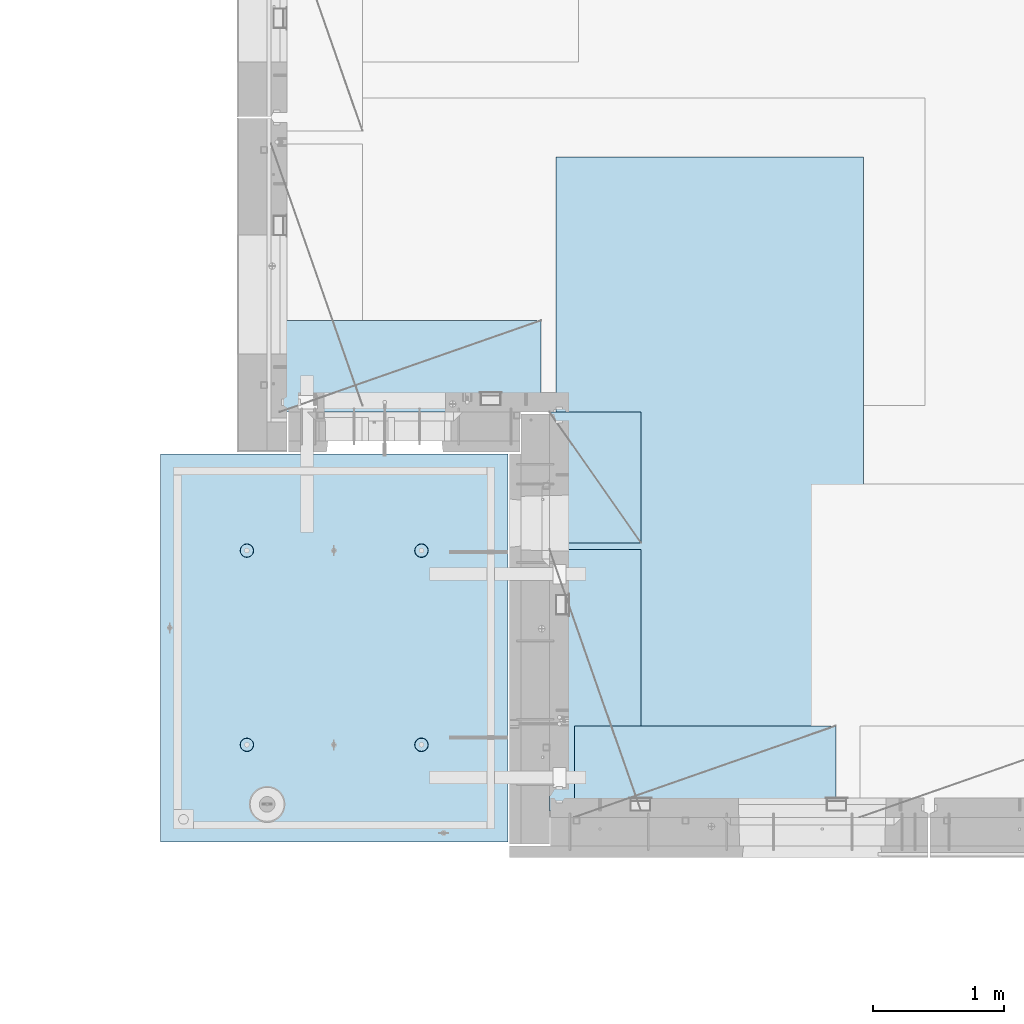
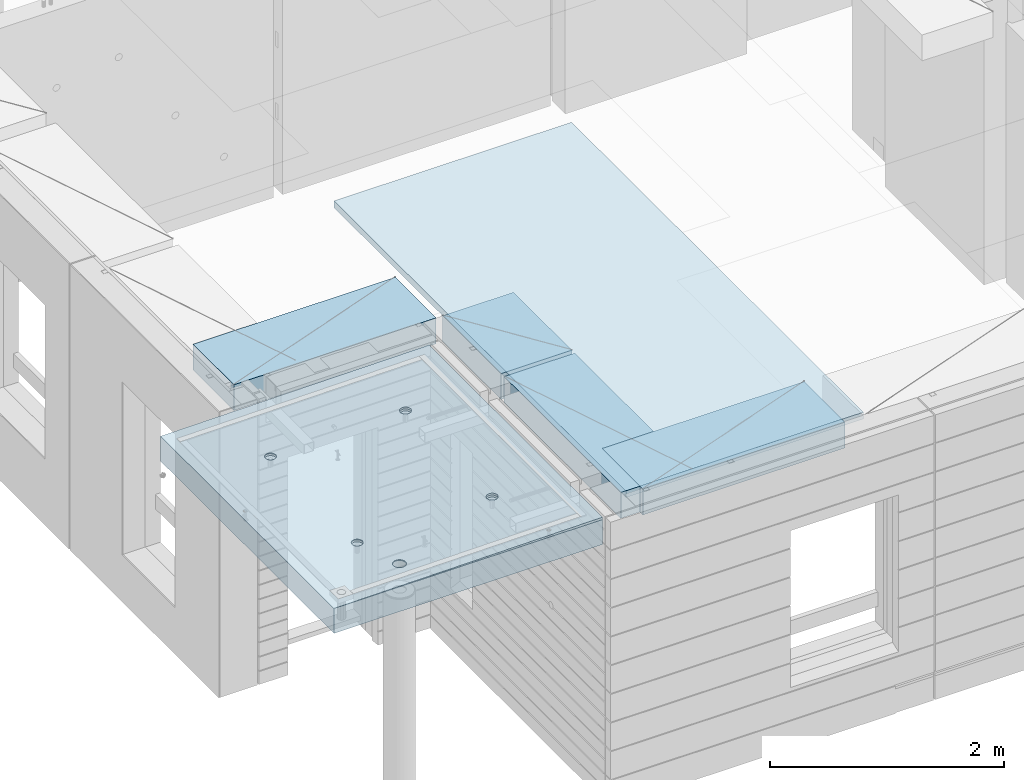
# One storey, part 200 of 350: 5 plates, 2 slabs, 6 elements without a shape of their own.
"""IFC2X3 building model written with IfcOpenShell, lengths in millimetres."""

from ifc_helpers import new_model, si_unit, frame, origin_with_axes, place, context, subcontext, project, spatial, faceted_brep, material, type_object, element, aggregate, save


model = new_model("IFC2X3")

# Units and contexts
model_context = context("Model", 3, precision=1e-05, world=origin_with_axes())
body_context = subcontext(model_context, "Body", "Model", "MODEL_VIEW")
ifc_project = project(units=[si_unit("LENGTHUNIT", "METRE", prefix="MILLI"), si_unit("AREAUNIT", "SQUARE_METRE"), si_unit("VOLUMEUNIT", "CUBIC_METRE"), si_unit("MASSUNIT", "GRAM", prefix="KILO"), si_unit("TIMEUNIT", "SECOND"), si_unit("PLANEANGLEUNIT", "RADIAN"), si_unit("SOLIDANGLEUNIT", "STERADIAN"), si_unit("THERMODYNAMICTEMPERATUREUNIT", "DEGREE_CELSIUS"), si_unit("LUMINOUSINTENSITYUNIT", "LUMEN")], contexts=[model_context])

# Site, building, storey
site_placement = place(None, origin_with_axes())
site = spatial("IfcSite", under=ifc_project, at=site_placement, CompositionType="ELEMENT")
building_placement = place(site_placement, origin_with_axes())
building = spatial("IfcBuilding", under=site, at=building_placement, CompositionType="ELEMENT")
storey_placement = place(building_placement, origin_with_axes())
storey = spatial("IfcBuildingStorey", under=building, at=storey_placement, Name="2", CompositionType="ELEMENT", Elevation=0.0)

# Assembly, slabs
assembly_1_placement = place(storey_placement, origin_with_axes())
assembly_1 = element("IfcElementAssembly", 1, at=assembly_1_placement, inside=storey, AssemblyPlace="NOTDEFINED", PredefinedType="REINFORCEMENT_UNIT")
ifc_material_1 = material(Name="CONCRETE/C35/45")
slab_type_1 = type_object("IfcSlabType", PredefinedType="NOTDEFINED")
slab_1_placement = place(assembly_1_placement, frame((9690.00344264774, 7659.99985681325, 87717.5), z_axis=(-1.0, 3.00000001838171e-08, 0.0), x_axis=(0.0, 1.0, 0.0)))
slab_1 = element("IfcSlab", 2, at=slab_1_placement, type_object=slab_type_1, material=ifc_material_1, PredefinedType="FLOOR", context=body_context, shape_type="Brep", body=[
    faceted_brep([(2970.0, 12.5, 2076.56396484375), (2970.0, 12.5, 2655.10375976563), (2970.0, 7.05330645262438, 2076.56396484375), (2970.0, 12.5, 0.0), (2969.99999999997, -12.5000027287315, -0.000215120240682154), (7.41420080885291e-08, 12.4999999999927, 0.0), (-7.41420080885291e-08, -12.5, -3.63797880709171e-12), (0.0, 12.5, 2655.00366210938), (2246.17288192116, -6.7539579669974, 610.235903379627), (2245.81872714612, 12.5, 611.325879700402), (2230.00000005311, 12.5, 608.820439463128), (2230.00000005311, -6.77809034052189, 607.672934085716), (2260.76019932669, -6.68392947182292, 617.673133503364), (2260.0890070157, 12.5, 618.596950465364), (2272.332530811, -6.57487936261168, 629.254531739907), (2271.41396524135, 12.5, 629.921908691014), (2279.75709784774, -6.43750647555862, 643.843854552742), (2278.68503600632, 12.5, 644.192188560603), (2282.30864751904, -6.2852774275234, 660.010915653605), (2281.19047624359, 12.5, 660.010915653605), (2279.73986529519, -6.13310092446045, 676.172377558725), (2278.68503600632, 12.5, 675.829642746608), (2272.30464795307, -5.995865551522, 690.747041485218), (2271.41396524135, 12.5, 690.099922616197), (2260.73231646608, -5.88698525390646, 702.310320338618), (2260.0890070157, 12.5, 701.424880841847), (2246.15564936427, -5.81709377811057, 709.732891570933), (2245.81872714612, 12.5, 708.695951606809), (2230.00000005311, -5.7930130083696, 712.290261666009), (2230.00000005311, 12.5, 711.201391844083), (2213.8443507625, -5.8170926610037, 709.732891507694), (2214.18127296011, 12.5, 708.695951606811), (2199.2676837145, -5.88698312871566, 702.310320236276), (2199.91099309052, 12.5, 701.424880841847), (2187.69535229405, -5.99586262571393, 690.747041382852), (2188.58603486487, 12.5, 690.099922616197), (2180.26013500581, -6.13309748387837, 676.172377495441), (2181.31496409991, 12.5, 675.829642746608), (2177.6913528026, -6.28527380865125, 660.010915653605), (2178.80952386264, 12.5, 660.010915653605), (2180.24290245339, -6.43750303260458, 643.843854616072), (2181.31496409991, 12.5, 644.192188560603), (2187.66746943631, -6.57487643294735, 629.254531842409), (2188.58603486487, 12.5, 629.921908691014), (2199.23980085403, -6.68392734277586, 617.673133605889), (2199.91099309052, 12.5, 618.596950465364), (2213.82711820565, -6.75395684751857, 610.235903443003), (2214.18127296011, 12.5, 611.325879700402), (761.172882674973, -6.75400078258826, 610.225900828256), (760.818727112381, 12.5, 611.315879572843), (745.000000019378, 12.5, 608.81043933557), (745.000000019378, -6.77813315729145, 607.662931409541), (775.760200790834, -6.68397228400863, 617.663131314152), (775.089006981969, 12.5, 618.586950337805), (787.33253283866, -6.57492216948594, 629.244530114656), (786.413965207619, 12.5, 629.911908563456), (794.757100236948, -6.437549275739, 643.833853637923), (793.685035972581, 12.5, 644.182188433044), (797.308650032492, -6.28532022031141, 660.000915526047), (796.190476209855, 12.5, 660.000915526047), (794.739867683551, -6.13314370981243, 676.162378218156), (793.685035972581, 12.5, 675.81964261905), (787.304649979378, -5.9959083302092, 690.737042854367), (786.413965207619, 12.5, 690.089922488638), (775.732317928869, -5.88702802728221, 702.300322270843), (775.089006981969, 12.5, 701.414880714288), (761.155650117242, -5.81713654809573, 709.722893864604), (760.818727112381, 12.5, 708.68595147925), (745.000000019378, -5.79305577717605, 712.280264084213), (745.000000019378, 12.5, 711.191391716524), (728.844349942063, -5.8171354309743, 709.722893801363), (729.181272926375, 12.5, 708.68595147925), (714.267682184241, -5.88702590207686, 702.300322168503), (714.910993056787, 12.5, 701.414880714288), (702.695350200273, -5.99590540440113, 690.737042752), (703.586034831136, 12.5, 690.089922488638), (695.260132549976, -6.1331402692449, 676.16237815487), (696.314964066174, 12.5, 675.81964261905), (692.691350221674, -6.28531660142471, 660.000915526047), (693.809523828902, 12.5, 660.000915526047), (695.242899996714, -6.43754583279951, 643.833853701251), (696.314964066174, 12.5, 644.182188433044), (702.667467341174, -6.57491923982161, 629.244530217156), (703.586034831136, 12.5, 629.911908563456), (714.239799322411, -6.68397015496157, 617.663131416677), (714.910993056787, 12.5, 618.586950337805), (728.827117384375, -6.75399966310943, 610.225900891632), (729.181272926375, 12.5, 611.315879572843), (760.941541335169, 5.82308796475991, 1945.93972725137), (760.818727091786, 12.5, 1946.31771062636), (744.999999998783, 12.5, 1943.81227038909), (744.999999998783, 5.79930078610778, 1943.4134192454), (775.320198478928, 5.89211475661432, 1953.2705735664), (775.089006961374, 12.5, 1953.58878139132), (786.72699673669, 5.99960498859582, 1964.68630888353), (786.413965187025, 12.5, 1964.91373961697), (794.045361100365, 6.13501286304381, 1979.06694274881), (793.685035951987, 12.5, 1979.18401948656), (796.560412832556, 6.28506439260673, 1995.00274657956), (796.190476189258, 12.5, 1995.00274657956), (794.028375046106, 6.43506412883289, 2010.93303130673), (793.685035951987, 12.5, 2010.82147367257), (786.699512721421, 6.57033645619231, 2025.29921596966), (786.413965187025, 12.5, 2025.09175354215), (775.292714461017, 6.67765930559835, 2036.69709108738), (775.089006961374, 12.5, 2036.41671176781), (760.924555276639, 6.74655103802797, 2044.01348819506), (760.818727091786, 12.5, 2043.68778253277), (744.999999998783, 6.7702873510425, 2046.53427709438), (744.999999998783, 12.5, 2046.19322277004), (729.075444741182, 6.7465521391714, 2044.01348813272), (729.18127290578, 12.5, 2043.68778253277), (714.70728560984, 6.67766140039021, 2036.6970909865), (714.910993036192, 12.5, 2036.41671176781), (703.300487415023, 6.57033934014908, 2025.29921586876), (703.586034810542, 12.5, 2025.09175354216), (695.971625143447, 6.43506752018584, 2010.93303124435), (696.314964045579, 12.5, 2010.82147367257), (693.439587377337, 6.28506795971771, 1995.00274657956), (693.809523808306, 12.5, 1995.00274657956), (695.954639089321, 6.13501625673962, 1979.06694281123), (696.314964045579, 12.5, 1979.18401948656), (703.273003399938, 5.99960787635064, 1964.68630898457), (703.586034810542, 12.5, 1964.91373961697), (714.679801592063, 5.89211685521877, 1953.27057366746), (714.910993036192, 12.5, 1953.58878139132), (729.058458682694, 5.82308906823164, 1945.93972731384), (729.18127290578, 12.5, 1946.31771062636), (2178.80952377932, 12.5, 1995.00274667064), (2178.43958429075, 6.28501659208268, 1995.00274667064), (2180.95463615188, 6.13496488021337, 1979.06694195729), (2181.31496401659, 12.5, 1979.18401957764), (2181.31496401659, 12.5, 2010.82147376364), (2180.97162220701, 6.43501616145659, 2010.93303228012), (2188.58603478155, 12.5, 2025.09175363323), (2188.3004849132, 6.57028798943793, 2025.29921775646), (2199.9109930072, 12.5, 2036.41671185888), (2199.70728378446, 6.6776100560528, 2036.6970935501), (2214.18127287679, 12.5, 2043.68778262385), (2214.07544376785, 6.74650079890853, 2044.0134911302), (2229.9999999698, 12.5, 2046.19322286112), (2229.9999999698, 6.77023601217661, 2046.53428024135), (2245.8187270628, 12.5, 2043.68778262385), (2245.924556192, 6.7464996977651, 2044.01349119253), (2260.08900693239, 12.5, 2036.41671185888), (2260.29271622843, 6.67760796126095, 2036.69709365098), (2271.41396515804, 12.5, 2025.09175363323), (2271.69951516527, 6.57028510548116, 2025.29921785736), (2278.685035923, 12.5, 2010.82147376364), (2279.02837792456, 6.43501277010364, 2010.9330323425), (2281.19047616027, 12.5, 1995.00274667064), (2281.56041586117, 6.2850130249717, 1995.00274667064), (2278.685035923, 12.5, 1979.18401957764), (2279.04536397983, 6.13496148651757, 1979.06694189487), (2271.41396515804, 12.5, 1964.91373970805), (2271.72699918216, 5.99955360403692, 1964.68630717681), (2260.08900693239, 12.5, 1953.5887814824), (2260.32020024797, 5.89206336568168, 1953.2705711827), (2245.8187270628, 12.5, 1946.31771071744), (2245.94154225154, 5.82303656973818, 1945.93972443295), (254.731823253564, 4.36849820162752, 1791.45731182264), (241.457918728614, 4.49348581883532, 1804.73121634759), (232.935547413403, 4.65097912067722, 1821.45731182264), (229.998938391112, 4.82556156541978, 1839.99833148514), (232.935547413403, 5.00014380698849, 1858.53935114764), (241.457918728614, 5.15763651921588, 1875.26544662269), (254.731823253564, 5.28262321809598, 1888.53935114764), (271.457918728614, 5.36286933471274, 1897.06172246285), (289.998938391112, 5.3905198200664, 1899.99833148514), (308.539958053609, 5.36286805199052, 1897.06172246285), (325.26605352866, 5.28262077822001, 1888.53935114764), (338.539958053609, 5.15763316099765, 1875.26544662269), (347.06232936882, 5.0001398591703, 1858.53935114764), (349.998938391112, 4.82555741442775, 1839.99833148514), (347.06232936882, 4.65097517284448, 1821.45731182264), (338.539958053609, 4.49348246061709, 1804.73121634759), (325.26605352866, 4.36849576173699, 1791.45731182264), (308.539958053609, 4.28824964510568, 1782.93494050743), (289.998938391112, 4.26059915976657, 1779.99833148514), (271.457918728614, 4.28825092784246, 1782.93494050743), (2199.67979976505, 5.89206546428613, 1953.27057128376), (2188.27300089649, 5.99955649179174, 1964.68630727784), (2229.9999999698, 5.79924938967451, 1943.41341627717), (2214.05845770835, 5.82303767320991, 1945.93972449542), (2188.58603478155, 12.5, 1964.91373970805), (2199.9109930072, 12.5, 1953.5887814824), (2214.18127287679, 12.5, 1946.31771071744), (2229.9999999698, 12.5, 1943.81227048017), (325.26605352866, 12.5, 1791.45731182264), (338.539958053609, 12.5, 1804.73121634759), (347.06232936882, 12.5, 1821.45731182264), (349.998938391112, 12.5, 1839.99833148514), (347.06232936882, 12.5, 1858.53935114764), (338.539958053609, 12.5, 1875.26544662269), (325.26605352866, 12.5, 1888.53935114764), (308.539958053609, 12.5, 1897.06172246285), (289.998938391112, 12.5, 1899.99833148514), (271.457918728614, 12.5, 1897.06172246285), (254.731823253564, 12.5, 1888.53935114764), (241.457918728614, 12.5, 1875.26544662269), (232.935547413403, 12.5, 1858.53935114764), (229.998938391112, 12.5, 1839.99833148514), (232.935547413403, 12.5, 1821.45731182264), (241.457918728614, 12.5, 1804.73121634759), (254.731823253564, 12.5, 1791.45731182264), (271.457918728614, 12.5, 1782.93494050743), (289.998938391112, 12.5, 1779.99833148514), (308.539958053609, 12.5, 1782.93494050743)], [[[0, 1, 2]], [[3, 0, 2, 4]], [[5, 3, 4, 6]], [[5, 6, 7]], [[8, 9, 10, 11]], [[12, 13, 9, 8]], [[14, 15, 13, 12]], [[16, 17, 15, 14]], [[18, 19, 17, 16]], [[20, 21, 19, 18]], [[21, 20, 22, 23]], [[23, 22, 24, 25]], [[25, 24, 26, 27]], [[27, 26, 28, 29]], [[29, 28, 30, 31]], [[31, 30, 32, 33]], [[33, 32, 34, 35]], [[35, 34, 36, 37]], [[37, 36, 38, 39]], [[40, 41, 39, 38]], [[42, 43, 41, 40]], [[44, 45, 43, 42]], [[46, 47, 45, 44]], [[11, 10, 47, 46]], [[48, 49, 50, 51]], [[52, 53, 49, 48]], [[54, 55, 53, 52]], [[56, 57, 55, 54]], [[58, 59, 57, 56]], [[60, 61, 59, 58]], [[61, 60, 62, 63]], [[63, 62, 64, 65]], [[65, 64, 66, 67]], [[67, 66, 68, 69]], [[69, 68, 70, 71]], [[71, 70, 72, 73]], [[73, 72, 74, 75]], [[75, 74, 76, 77]], [[77, 76, 78, 79]], [[80, 81, 79, 78]], [[82, 83, 81, 80]], [[84, 85, 83, 82]], [[86, 87, 85, 84]], [[51, 50, 87, 86]], [[88, 89, 90, 91]], [[92, 93, 89, 88]], [[94, 95, 93, 92]], [[96, 97, 95, 94]], [[98, 99, 97, 96]], [[100, 101, 99, 98]], [[102, 103, 101, 100]], [[104, 105, 103, 102]], [[105, 104, 106, 107]], [[107, 106, 108, 109]], [[109, 108, 110, 111]], [[111, 110, 112, 113]], [[113, 112, 114, 115]], [[115, 114, 116, 117]], [[117, 116, 118, 119]], [[119, 118, 120, 121]], [[121, 120, 122, 123]], [[124, 125, 123, 122]], [[126, 127, 125, 124]], [[91, 90, 127, 126]], [[128, 129, 130, 131]], [[132, 133, 129, 128]], [[134, 135, 133, 132]], [[136, 137, 135, 134]], [[138, 139, 137, 136]], [[140, 141, 139, 138]], [[142, 143, 141, 140]], [[144, 145, 143, 142]], [[145, 144, 146, 147]], [[147, 146, 148, 149]], [[149, 148, 150, 151]], [[151, 150, 152, 153]], [[153, 152, 154, 155]], [[155, 154, 156, 157]], [[157, 156, 158, 159]], [[4, 2, 1, 7, 6], [160, 161, 162, 163, 164, 165, 166, 167, 168, 169, 170, 171, 172, 173, 174, 175, 176, 177, 178, 179], [180, 181, 130, 129, 133, 135, 137, 139, 141, 143, 145, 147, 149, 151, 153, 155, 157, 159, 182, 183], [124, 122, 120, 118, 116, 114, 112, 110, 108, 106, 104, 102, 100, 98, 96, 94, 92, 88, 91, 126], [84, 82, 80, 78, 76, 74, 72, 70, 68, 66, 64, 62, 60, 58, 56, 54, 52, 48, 51, 86], [44, 42, 40, 38, 36, 34, 32, 30, 28, 26, 24, 22, 20, 18, 16, 14, 12, 8, 11, 46]], [[131, 130, 181, 184]], [[180, 185, 184, 181]], [[183, 186, 185, 180]], [[182, 187, 186, 183]], [[159, 158, 187, 182]], [[0, 3, 5, 7, 1], [188, 189, 190, 191, 192, 193, 194, 195, 196, 197, 198, 199, 200, 201, 202, 203, 204, 205, 206, 207], [156, 154, 152, 150, 148, 146, 144, 142, 140, 138, 136, 134, 132, 128, 131, 184, 185, 186, 187, 158], [93, 95, 97, 99, 101, 103, 105, 107, 109, 111, 113, 115, 117, 119, 121, 123, 125, 127, 90, 89], [53, 55, 57, 59, 61, 63, 65, 67, 69, 71, 73, 75, 77, 79, 81, 83, 85, 87, 50, 49], [13, 15, 17, 19, 21, 23, 25, 27, 29, 31, 33, 35, 37, 39, 41, 43, 45, 47, 10, 9]], [[178, 206, 205, 179]], [[177, 207, 206, 178]], [[176, 188, 207, 177]], [[175, 189, 188, 176]], [[174, 190, 189, 175]], [[173, 191, 190, 174]], [[172, 192, 191, 173]], [[171, 193, 192, 172]], [[170, 194, 193, 171]], [[169, 195, 194, 170]], [[168, 196, 195, 169]], [[167, 197, 196, 168]], [[166, 198, 197, 167]], [[165, 199, 198, 166]], [[164, 200, 199, 165]], [[163, 201, 200, 164]], [[162, 202, 201, 163]], [[161, 203, 202, 162]], [[160, 204, 203, 161]], [[179, 205, 204, 160]]]),
])
slab_type_2 = type_object("IfcSlabType", PredefinedType="NOTDEFINED")
slab_2_placement = place(assembly_1_placement, frame((9690.00344264774, 7659.99985681325, 87575.0), z_axis=(-0.999999999997437, -2.26400000064461e-06, 0.0), x_axis=(-2.2639999995273e-06, 0.999999999997437, 0.0)))
slab_2 = element("IfcSlab", 3, at=slab_2_placement, type_object=slab_type_2, material=ifc_material_1, PredefinedType="FLOOR", context=body_context, shape_type="Brep", body=[
    faceted_brep([(2245.45536387143, -110.0, 1947.44471589559), (2259.39379322965, -110.0, 1954.54665968234), (2270.4554059745, -110.0, 1965.60822114567), (2277.55741437973, -110.0, 1979.54661757913), (2280.00462438004, -110.0, 1994.99746162528), (2277.55748600988, -110.0, 2010.44831701654), (2270.45554222312, -110.0, 2024.38674637476), (2259.39398075979, -110.0, 2035.44835911961), (2245.45558432633, -110.0, 2042.55036752485), (2230.00474028018, -110.0, 2044.99757752515), (2214.55388488892, -110.0, 2042.55043915498), (2200.6154555307, -110.0, 2035.44849536823), (2189.55384278585, -110.0, 2024.3869339049), (2182.45183438062, -110.0, 2010.44853747144), (2180.00462438031, -110.0, 1994.99769342529), (2182.45176275048, -110.0, 1979.54683803403), (2189.55370653723, -110.0, 1965.60840867581), (2200.61526800056, -110.0, 1954.54679593096), (2214.55366443402, -110.0, 1947.44478752572), (2230.00450848018, -110.0, 1944.99757752542), (2260.09353534512, -130.0, 1953.58354259084), (2245.82323862122, -130.0, 1946.3125049044), (2271.41851982199, -130.0, 1964.9084745652), (2278.68962366544, -130.0, 1979.17873758041), (2281.19510057052, -130.0, 1994.99745886576), (2278.68969700106, -130.0, 2010.81619176633), (2271.41865931462, -130.0, 2025.08648849022), (2260.09372734026, -130.0, 2036.4114729671), (2245.82346432505, -130.0, 2043.68257681055), (2230.0047430397, -130.0, 2046.18805371562), (2214.18601013913, -130.0, 2043.68265014617), (2199.91571341524, -130.0, 2036.41161245973), (2188.59072893836, -130.0, 2025.08668048537), (2181.31962509491, -130.0, 2010.81641747016), (2178.81414818984, -130.0, 1994.99769618481), (2181.31955175929, -130.0, 1979.17896328424), (2188.59058944573, -130.0, 1964.90866656035), (2199.91552142009, -130.0, 1953.58368208347), (2214.1857844353, -130.0, 1946.31257824002), (2230.00450572065, -130.0, 1943.80710133495), (760.455363904408, -110.0, 1947.44815803451), (774.393793262629, -110.0, 1954.55010182126), (785.455406007481, -110.0, 1965.61166328459), (792.557414412711, -110.0, 1979.55005971805), (795.004624413019, -110.0, 1995.00090376421), (792.557486042851, -110.0, 2010.45175915546), (785.455542256102, -110.0, 2024.39018851368), (774.393980792767, -110.0, 2035.45180125853), (760.455584359308, -110.0, 2042.55380966377), (745.004740313152, -110.0, 2045.00101966407), (729.553884921896, -110.0, 2042.55388129391), (715.615455563677, -110.0, 2035.45193750716), (704.553842818825, -110.0, 2024.39037604382), (697.451834413594, -110.0, 2010.45197961036), (695.004624413286, -110.0, 1995.00113556421), (697.451762783454, -110.0, 1979.55028017295), (704.553706570203, -110.0, 1965.61185081473), (715.615268033538, -110.0, 1954.55023806988), (729.553664466996, -110.0, 1947.44822966465), (745.004508513151, -110.0, 1945.00101966434), (760.823238654199, -130.0, 1946.31594704332), (745.004505753628, -130.0, 1943.81054347387), (775.093535378091, -130.0, 1953.58698472976), (786.418519854964, -130.0, 1964.91191670413), (793.689623698416, -130.0, 1979.18217971933), (796.195100603492, -130.0, 1995.00090100468), (793.689697034035, -130.0, 2010.81963390525), (786.418659347601, -130.0, 2025.08993062915), (775.093727373234, -130.0, 2036.41491510602), (760.823464358025, -130.0, 2043.68601894947), (745.004743072675, -130.0, 2046.19149585455), (729.186010172105, -130.0, 2043.68609228509), (714.915713448214, -130.0, 2036.41505459866), (703.590728971341, -130.0, 2025.09012262429), (696.319625127888, -130.0, 2010.81985960908), (693.814148222813, -130.0, 1995.00113832373), (696.319551792269, -130.0, 1979.18240542316), (703.590589478705, -130.0, 1964.91210869927), (714.915521453071, -130.0, 1953.5871242224), (729.185784468278, -130.0, 1946.31602037894), (2970.0, -130.0, 1.11504050437361e-09), (0.0, -130.0, -3.63797880709171e-12), (0.0, 130.0, -1.81898940354586e-12), (2970.0, 130.0, 1.11504050437361e-09), (2970.0048828125, -130.0, 2076.55712890625), (2970.0048828125, 130.0, 2076.55712890625), (2970.00610351563, -130.0, 2655.0966796875), (2970.00610351563, 130.0, 2655.0966796875), (0.00277573079893045, -130.0, 2655.00366210937), (0.00277573079893045, 130.0, 2655.00366210937), (325.270206125839, 130.0, 1791.45655785112), (338.544141419662, 130.0, 1804.73043160713), (347.066551505941, 130.0, 1821.45650732727), (350.003203506308, 130.0, 1839.99752018266), (347.066637462108, 130.0, 1858.53854665217), (338.544304918008, 130.0, 1875.26466188203), (325.270431162006, 130.0, 1888.53859717586), (308.544355441856, 130.0, 1897.06100726213), (290.003342586469, 130.0, 1899.9976592625), (271.462316116962, 130.0, 1897.0610932183), (254.7362008871, 130.0, 1888.5387606742), (241.462265593274, 130.0, 1875.2648869182), (232.939855506997, 130.0, 1858.53881119805), (230.00320350663, 130.0, 1839.99779834266), (232.93976955083, 130.0, 1821.45677187316), (241.462102094929, 130.0, 1804.73065664329), (254.735975850932, 130.0, 1791.45672134947), (271.462051571081, 130.0, 1782.93431126319), (290.003064426469, 130.0, 1779.99765926282), (308.544090895975, 130.0, 1782.93422530702), (308.544090895975, -130.0, 1782.93422530702), (290.003064426469, -130.0, 1779.99765926282), (325.270206125839, -130.0, 1791.45655785112), (338.544141419662, -130.0, 1804.73043160713), (347.066551505941, -130.0, 1821.45650732727), (350.003203506308, -130.0, 1839.99752018266), (347.066637462108, -130.0, 1858.53854665217), (338.544304918008, -130.0, 1875.26466188203), (325.270431162006, -130.0, 1888.53859717586), (308.544355441856, -130.0, 1897.06100726213), (290.003342586469, -130.0, 1899.9976592625), (271.462316116962, -130.0, 1897.0610932183), (254.7362008871, -130.0, 1888.5387606742), (241.462265593274, -130.0, 1875.2648869182), (232.939855506997, -130.0, 1858.53881119805), (230.00320350663, -130.0, 1839.99779834266), (232.93976955083, -130.0, 1821.45677187316), (241.462102094929, -130.0, 1804.73065664329), (254.735975850932, -130.0, 1791.45672134947), (271.462051571081, -130.0, 1782.93431126319), (760.452269390758, -110.0, 612.446326984578), (774.390698748979, -110.0, 619.548270771327), (785.452311493831, -110.0, 630.609832234661), (792.554319899062, -110.0, 644.54822866812), (795.001529899369, -110.0, 659.999072714278), (792.554391529202, -110.0, 675.449928105532), (785.452447742453, -110.0, 689.388357463751), (774.390886279118, -110.0, 700.449970208605), (760.452489845658, -110.0, 707.551978613836), (745.001645799503, -110.0, 709.999188614142), (729.550790408246, -110.0, 707.552050243974), (715.612361050027, -110.0, 700.450106457225), (704.550748305175, -110.0, 689.388544993892), (697.448739899944, -110.0, 675.450148560432), (695.001529899637, -110.0, 659.999304514276), (697.448668269804, -110.0, 644.54844912302), (704.550612056553, -110.0, 630.610019764801), (715.612173519889, -110.0, 619.548407019947), (729.550569953346, -110.0, 612.446398614717), (745.001413999502, -110.0, 609.999188614411), (760.820144140549, -130.0, 611.314115993395), (745.001411239979, -130.0, 608.808712423936), (775.090440864442, -130.0, 618.585153679829), (786.415425341314, -130.0, 629.910085654195), (793.686529184766, -130.0, 644.180348669403), (796.192006089843, -130.0, 659.999069954752), (793.686602520385, -130.0, 675.817802855323), (786.415564833951, -130.0, 690.088099579216), (775.090632859585, -130.0, 701.41308405609), (760.820369844376, -130.0, 708.68418789954), (745.001648559026, -130.0, 711.189664804615), (729.182915658455, -130.0, 708.684261235159), (714.912618934564, -130.0, 701.413223548725), (703.587634457692, -130.0, 690.088291574357), (696.316530614238, -130.0, 675.81802855915), (693.811053709163, -130.0, 659.999307273802), (696.316457278619, -130.0, 644.180574373229), (703.587494965055, -130.0, 629.910277649336), (714.912426939421, -130.0, 618.585293172464), (729.182689954629, -130.0, 611.314189329014), (2245.45226944368, -110.0, 612.452884882137), (2259.3906988019, -110.0, 619.554828668886), (2270.45231154675, -110.0, 630.61639013222), (2277.55431995199, -110.0, 644.554786565679), (2280.00152995229, -110.0, 660.005630611837), (2277.55439158212, -110.0, 675.456486003091), (2270.45244779537, -110.0, 689.39491536131), (2259.39088633204, -110.0, 700.456528106164), (2245.45248989858, -110.0, 707.558536511395), (2230.00164585242, -110.0, 710.005746511701), (2214.55079046117, -110.0, 707.558608141533), (2200.61236110295, -110.0, 700.456664354784), (2189.5507483581, -110.0, 689.395102891451), (2182.44873995286, -110.0, 675.456706457991), (2180.00152995256, -110.0, 660.005862411836), (2182.44866832273, -110.0, 644.555007020579), (2189.55061210948, -110.0, 630.61657766236), (2200.61217357281, -110.0, 619.554964917506), (2214.55057000627, -110.0, 612.452956512276), (2230.00141405243, -110.0, 610.00574651197), (2245.82014419347, -130.0, 611.320673890954), (2230.0014112929, -130.0, 608.815270321495), (2260.09044091736, -130.0, 618.591711577388), (2271.41542539424, -130.0, 629.916643551753), (2278.68652923769, -130.0, 644.186906566962), (2281.19200614276, -130.0, 660.005627852312), (2278.68660257331, -130.0, 675.824360752882), (2271.41556488687, -130.0, 690.094657476773), (2260.09063291251, -130.0, 701.419641953647), (2245.8203698973, -130.0, 708.690745797099), (2230.00164861195, -130.0, 711.196222702174), (2214.18291571138, -130.0, 708.690819132718), (2199.91261898749, -130.0, 701.419781446282), (2188.58763451061, -130.0, 690.094849471916), (2181.31653066716, -130.0, 675.824586456709), (2178.81105376209, -130.0, 660.005865171361), (2181.31645733154, -130.0, 644.187132270788), (2188.58749501798, -130.0, 629.916835546896), (2199.91242699234, -130.0, 618.591851070023), (2214.18269000755, -130.0, 611.320747226573)], [[[0, 1, 2, 3, 4, 5, 6, 7, 8, 9, 10, 11, 12, 13, 14, 15, 16, 17, 18, 19]], [[20, 1, 0, 21]], [[22, 2, 1, 20]], [[23, 3, 2, 22]], [[24, 4, 3, 23]], [[25, 5, 4, 24]], [[26, 6, 5, 25]], [[27, 7, 6, 26]], [[28, 8, 7, 27]], [[29, 9, 8, 28]], [[30, 10, 9, 29]], [[31, 11, 10, 30]], [[32, 12, 11, 31]], [[33, 13, 12, 32]], [[34, 14, 13, 33]], [[35, 15, 14, 34]], [[36, 16, 15, 35]], [[37, 17, 16, 36]], [[38, 18, 17, 37]], [[39, 19, 18, 38]], [[21, 0, 19, 39]], [[40, 41, 42, 43, 44, 45, 46, 47, 48, 49, 50, 51, 52, 53, 54, 55, 56, 57, 58, 59]], [[60, 40, 59, 61]], [[62, 41, 40, 60]], [[63, 42, 41, 62]], [[64, 43, 42, 63]], [[65, 44, 43, 64]], [[66, 45, 44, 65]], [[67, 46, 45, 66]], [[68, 47, 46, 67]], [[69, 48, 47, 68]], [[70, 49, 48, 69]], [[71, 50, 49, 70]], [[72, 51, 50, 71]], [[73, 52, 51, 72]], [[74, 53, 52, 73]], [[75, 54, 53, 74]], [[76, 55, 54, 75]], [[77, 56, 55, 76]], [[78, 57, 56, 77]], [[79, 58, 57, 78]], [[61, 59, 58, 79]], [[80, 81, 82, 83]], [[84, 80, 83, 85]], [[86, 84, 85, 87]], [[88, 86, 87, 89]], [[81, 88, 89, 82]], [[87, 85, 83, 82, 89], [90, 91, 92, 93, 94, 95, 96, 97, 98, 99, 100, 101, 102, 103, 104, 105, 106, 107, 108, 109]], [[110, 109, 108, 111]], [[112, 90, 109, 110]], [[113, 91, 90, 112]], [[114, 92, 91, 113]], [[115, 93, 92, 114]], [[116, 94, 93, 115]], [[117, 95, 94, 116]], [[118, 96, 95, 117]], [[119, 97, 96, 118]], [[120, 98, 97, 119]], [[121, 99, 98, 120]], [[122, 100, 99, 121]], [[123, 101, 100, 122]], [[124, 102, 101, 123]], [[125, 103, 102, 124]], [[126, 104, 103, 125]], [[127, 105, 104, 126]], [[128, 106, 105, 127]], [[129, 107, 106, 128]], [[111, 108, 107, 129]], [[130, 131, 132, 133, 134, 135, 136, 137, 138, 139, 140, 141, 142, 143, 144, 145, 146, 147, 148, 149]], [[150, 130, 149, 151]], [[152, 131, 130, 150]], [[153, 132, 131, 152]], [[154, 133, 132, 153]], [[155, 134, 133, 154]], [[156, 135, 134, 155]], [[157, 136, 135, 156]], [[158, 137, 136, 157]], [[159, 138, 137, 158]], [[160, 139, 138, 159]], [[161, 140, 139, 160]], [[162, 141, 140, 161]], [[163, 142, 141, 162]], [[164, 143, 142, 163]], [[165, 144, 143, 164]], [[166, 145, 144, 165]], [[167, 146, 145, 166]], [[168, 147, 146, 167]], [[169, 148, 147, 168]], [[151, 149, 148, 169]], [[170, 171, 172, 173, 174, 175, 176, 177, 178, 179, 180, 181, 182, 183, 184, 185, 186, 187, 188, 189]], [[190, 170, 189, 191]], [[192, 171, 170, 190]], [[193, 172, 171, 192]], [[194, 173, 172, 193]], [[195, 174, 173, 194]], [[196, 175, 174, 195]], [[197, 176, 175, 196]], [[198, 177, 176, 197]], [[199, 178, 177, 198]], [[200, 179, 178, 199]], [[201, 180, 179, 200]], [[202, 181, 180, 201]], [[203, 182, 181, 202]], [[204, 183, 182, 203]], [[205, 184, 183, 204]], [[206, 185, 184, 205]], [[207, 186, 185, 206]], [[208, 187, 186, 207]], [[209, 188, 187, 208]], [[191, 189, 188, 209]], [[80, 84, 86, 88, 81], [37, 36, 35, 34, 33, 32, 31, 30, 29, 28, 27, 26, 25, 24, 23, 22, 20, 21, 39, 38], [208, 207, 206, 205, 204, 203, 202, 201, 200, 199, 198, 197, 196, 195, 194, 193, 192, 190, 191, 209], [168, 167, 166, 165, 164, 163, 162, 161, 160, 159, 158, 157, 156, 155, 154, 153, 152, 150, 151, 169], [128, 127, 126, 125, 124, 123, 122, 121, 120, 119, 118, 117, 116, 115, 114, 113, 112, 110, 111, 129], [78, 77, 76, 75, 74, 73, 72, 71, 70, 69, 68, 67, 66, 65, 64, 63, 62, 60, 61, 79]]]),
])
aggregate(assembly_1, [slab_1, slab_2])

# Assembly, plate
assembly_2_placement = place(storey_placement, origin_with_axes())
assembly_2 = element("IfcElementAssembly", 4, at=assembly_2_placement, inside=storey, Name="Steel Assembly", AssemblyPlace="NOTDEFINED", PredefinedType="NOTDEFINED")
ifc_material_2 = material()
plate_type_1 = type_object("IfcPlateType", PredefinedType="NOTDEFINED")
plate_1_placement = place(assembly_2_placement, frame((10060.0, 7900.0, 87695.1), z_axis=(0.0, 1.0, 0.0), x_axis=(1.0, 0.0, 0.0)))
plate_1 = element("IfcPlate", 5, at=plate_1_placement, type_object=plate_type_1, material=ifc_material_2, context=body_context, shape_type="Brep", body=[
    faceted_brep([(0.0, -35.0, 0.0), (0.0, -35.0, 5000.0), (0.0, 35.0, 5000.0), (0.0, 35.0, 0.0), (2349.99951171875, -35.0, 5000.0), (2349.99951171875, 35.0, 5000.0), (2350.0, -35.0, 0.0), (2350.0, 35.0, 0.0)], [[[0, 1, 2, 3]], [[1, 4, 5, 2]], [[4, 6, 7, 5]], [[6, 0, 3, 7]], [[5, 7, 3, 2]], [[6, 4, 1, 0]]]),
])
aggregate(assembly_2, [plate_1])

assembly_3_placement = place(storey_placement, origin_with_axes())
assembly_3 = element("IfcElementAssembly", 6, at=assembly_3_placement, inside=storey, Name="Steel Assembly", AssemblyPlace="NOTDEFINED", PredefinedType="NOTDEFINED")
plate_type_2 = type_object("IfcPlateType", PredefinedType="NOTDEFINED")
plate_2_placement = place(assembly_3_placement, frame((7945.00085423865, 10950.0001036336, 87595.3), z_axis=(0.0, 1.0, 0.0), x_axis=(1.0, 0.0, 0.0)))
plate_2 = element("IfcPlate", 7, at=plate_2_placement, type_object=plate_type_2, material=ifc_material_2, Name="RE1", context=body_context, shape_type="Brep", body=[
    faceted_brep([(1.81898940354586e-12, -135.0, 1.81898940354586e-12), (0.0, -135.0, 699.999999999996), (0.0, 135.0, 699.999999999996), (1.81898940354586e-12, 135.0, 1.81898940354586e-12), (1999.99951171875, -135.0, 699.999999999993), (1999.99951171875, 135.0, 699.999999999993), (2000.0, -135.0, -3.63797880709171e-12), (2000.0, 135.0, -3.63797880709171e-12)], [[[0, 1, 2, 3]], [[1, 4, 5, 2]], [[4, 6, 7, 5]], [[6, 0, 3, 7]], [[5, 7, 3, 2]], [[6, 4, 1, 0]]]),
])
aggregate(assembly_3, [plate_2])

assembly_4_placement = place(storey_placement, origin_with_axes())
assembly_4 = element("IfcElementAssembly", 8, at=assembly_4_placement, inside=storey, Name="Steel Assembly", AssemblyPlace="NOTDEFINED", PredefinedType="NOTDEFINED")
plate_3_placement = place(assembly_4_placement, frame((10009.9998779297, 9900.0, 87595.3), z_axis=(1.0, 0.0, 0.0), x_axis=(0.0, -1.0, 0.0)))
plate_3 = element("IfcPlate", 9, at=plate_3_placement, type_object=plate_type_2, material=ifc_material_2, Name="RE1", context=body_context, shape_type="Brep", body=[
    faceted_brep([(1.81898940354586e-12, -135.0, 1.81898940354586e-12), (0.0, -135.0, 699.999999999996), (0.0, 135.0, 699.999999999996), (1.81898940354586e-12, 135.0, 1.81898940354586e-12), (1999.99951171875, -135.0, 699.999999999993), (1999.99951171875, 135.0, 699.999999999993), (2000.0, -135.0, -3.63797880709171e-12), (2000.0, 135.0, -3.63797880709171e-12)], [[[0, 1, 2, 3]], [[1, 4, 5, 2]], [[4, 6, 7, 5]], [[6, 0, 3, 7]], [[5, 7, 3, 2]], [[6, 4, 1, 0]]]),
])
aggregate(assembly_4, [plate_3])

assembly_5_placement = place(storey_placement, origin_with_axes())
assembly_5 = element("IfcElementAssembly", 10, at=assembly_5_placement, inside=storey, Name="Steel Assembly", AssemblyPlace="NOTDEFINED", PredefinedType="NOTDEFINED")
plate_4_placement = place(assembly_5_placement, frame((10009.9999999293, 10950.0, 87595.3), z_axis=(1.0, 0.0, 0.0), x_axis=(0.0, -1.0, 0.0)))
plate_4 = element("IfcPlate", 11, at=plate_4_placement, type_object=plate_type_2, material=ifc_material_2, Name="RE1_1/2", context=body_context, shape_type="Brep", body=[
    faceted_brep([(1.81898940354586e-12, -135.0, 1.81898940354586e-12), (0.0, -135.0, 699.999999999996), (0.0, 135.0, 699.999999999996), (1.81898940354586e-12, 135.0, 1.81898940354586e-12), (999.99951171875, -135.0, 700.0), (999.99951171875, 135.0, 700.0), (1000.0, -135.0, 0.0), (1000.0, 135.0, 0.0)], [[[0, 1, 2, 3]], [[1, 4, 5, 2]], [[4, 6, 7, 5]], [[6, 0, 3, 7]], [[5, 7, 3, 2]], [[6, 4, 1, 0]]]),
])
aggregate(assembly_5, [plate_4])

assembly_6_placement = place(storey_placement, origin_with_axes())
assembly_6 = element("IfcElementAssembly", 12, at=assembly_6_placement, inside=storey, Name="Steel Assembly", AssemblyPlace="NOTDEFINED", PredefinedType="NOTDEFINED")
plate_5_placement = place(assembly_6_placement, frame((10200.0008542386, 7850.00010363356, 87595.3), z_axis=(0.0, 1.0, 0.0), x_axis=(1.0, 0.0, 0.0)))
plate_5 = element("IfcPlate", 13, at=plate_5_placement, type_object=plate_type_2, material=ifc_material_2, Name="RE1", context=body_context, shape_type="Brep", body=[
    faceted_brep([(1.81898940354586e-12, -135.0, 1.81898940354586e-12), (0.0, -135.0, 699.999999999996), (0.0, 135.0, 699.999999999996), (1.81898940354586e-12, 135.0, 1.81898940354586e-12), (1999.99951171875, -135.0, 699.999999999993), (1999.99951171875, 135.0, 699.999999999993), (2000.0, -135.0, -3.63797880709171e-12), (2000.0, 135.0, -3.63797880709171e-12)], [[[0, 1, 2, 3]], [[1, 4, 5, 2]], [[4, 6, 7, 5]], [[6, 0, 3, 7]], [[5, 7, 3, 2]], [[6, 4, 1, 0]]]),
])
aggregate(assembly_6, [plate_5])

save(model, "model.ifc")
